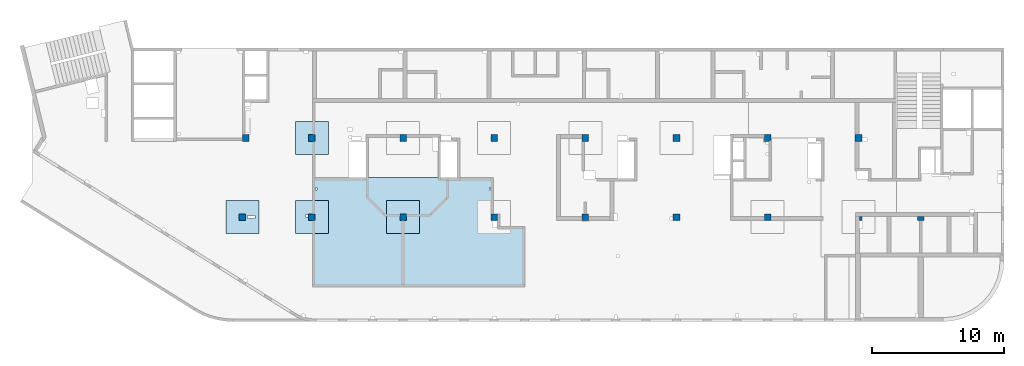
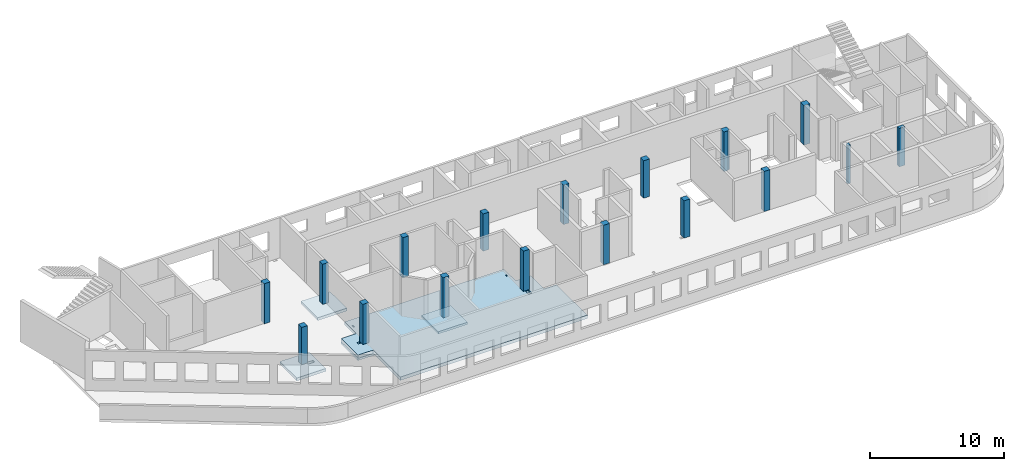
# One storey, part 1 of 10: 17 columns, 5 slabs.
"""IFC4 building model written with IfcOpenShell, lengths in millimetres."""

from ifc_helpers import new_model, entity, si_unit, converted_unit, derived_unit, direction, frame, origin, place, context, subcontext, project, spatial, indexed_curve, outline, extrude, source, transform, mapped, material, type_object, type_shapes, element, save


model = new_model("IFC4")

# Units and contexts
model_context = context("Model", 3, precision=0.01, world=origin(), true_north=direction((6.12303176911189e-17, 1.0)))
plan_context = context("Plan", 3, precision=0.01, world=origin(), true_north=direction((6.12303176911189e-17, 1.0)))
body_context = subcontext(model_context, "Body", "Model", "MODEL_VIEW")
ifc_project = project(units=[si_unit("LENGTHUNIT", "METRE", prefix="MILLI"), si_unit("AREAUNIT", "SQUARE_METRE"), si_unit("VOLUMEUNIT", "CUBIC_METRE"), converted_unit("PLANEANGLEUNIT", "DEGREE", entity("IfcRatioMeasure", 0.0174532925199433), si_unit("PLANEANGLEUNIT", "RADIAN"), dimensions=[0, 0, 0, 0, 0, 0, 0]), si_unit("MASSUNIT", "GRAM", prefix="KILO"), derived_unit("MASSDENSITYUNIT", [(si_unit("MASSUNIT", "GRAM", prefix="KILO"), 1), (si_unit("LENGTHUNIT", "METRE"), -3)]), derived_unit("MOMENTOFINERTIAUNIT", [(si_unit("LENGTHUNIT", "METRE"), 4)]), si_unit("TIMEUNIT", "SECOND"), si_unit("FREQUENCYUNIT", "HERTZ"), si_unit("THERMODYNAMICTEMPERATUREUNIT", "DEGREE_CELSIUS"), derived_unit("THERMALTRANSMITTANCEUNIT", [(si_unit("MASSUNIT", "GRAM", prefix="KILO"), 1), (si_unit("THERMODYNAMICTEMPERATUREUNIT", "KELVIN"), -1), (si_unit("TIMEUNIT", "SECOND"), -3)]), derived_unit("VOLUMETRICFLOWRATEUNIT", [(si_unit("LENGTHUNIT", "METRE"), 3), (si_unit("TIMEUNIT", "SECOND"), -1)]), derived_unit("MASSFLOWRATEUNIT", [(si_unit("MASSUNIT", "GRAM", prefix="KILO"), 1), (si_unit("TIMEUNIT", "SECOND"), -1)]), derived_unit("ROTATIONALFREQUENCYUNIT", [(si_unit("TIMEUNIT", "SECOND"), -1)]), si_unit("ELECTRICCURRENTUNIT", "AMPERE"), si_unit("ELECTRICVOLTAGEUNIT", "VOLT"), si_unit("POWERUNIT", "WATT"), si_unit("FORCEUNIT", "NEWTON", prefix="KILO"), si_unit("ILLUMINANCEUNIT", "LUX"), si_unit("LUMINOUSFLUXUNIT", "LUMEN"), si_unit("LUMINOUSINTENSITYUNIT", "CANDELA"), derived_unit("USERDEFINED", [(si_unit("MASSUNIT", "GRAM", prefix="KILO"), -1), (si_unit("LENGTHUNIT", "METRE"), -2), (si_unit("TIMEUNIT", "SECOND"), 3), (si_unit("LUMINOUSFLUXUNIT", "LUMEN"), 1)]), derived_unit("LINEARVELOCITYUNIT", [(si_unit("LENGTHUNIT", "METRE"), 1), (si_unit("TIMEUNIT", "SECOND"), -1)]), si_unit("PRESSUREUNIT", "PASCAL"), derived_unit("USERDEFINED", [(si_unit("LENGTHUNIT", "METRE"), -2), (si_unit("MASSUNIT", "GRAM", prefix="KILO"), 1), (si_unit("TIMEUNIT", "SECOND"), -2)]), derived_unit("LINEARFORCEUNIT", [(si_unit("MASSUNIT", "GRAM", prefix="KILO"), 1), (si_unit("LENGTHUNIT", "METRE"), 1), (si_unit("TIMEUNIT", "SECOND"), -2), (si_unit("LENGTHUNIT", "METRE"), -1)]), derived_unit("PLANARFORCEUNIT", [(si_unit("MASSUNIT", "GRAM", prefix="KILO"), 1), (si_unit("LENGTHUNIT", "METRE"), 1), (si_unit("TIMEUNIT", "SECOND"), -2), (si_unit("LENGTHUNIT", "METRE"), -2)])], contexts=[model_context, plan_context])

# Site, building, storey
site_placement = place(None, origin())
site = spatial("IfcSite", under=ifc_project, at=site_placement, CompositionType="ELEMENT")
building_placement = place(site_placement, origin())
building = spatial("IfcBuilding", under=site, at=building_placement, CompositionType="ELEMENT")
storey_placement = place(building_placement, frame((0.0, 0.0, 4200.0)))
storey = spatial("IfcBuildingStorey", under=building, at=storey_placement, CompositionType="ELEMENT", Elevation=4200.0)

# Columns
ifc_material = material()
column_type_1 = type_object("IfcColumnType", PredefinedType="COLUMN", material=ifc_material)
shared_shape_1 = source(origin(), body_context, "Body", "SweptSolid", [
    extrude(outline(indexed_curve([(-249.999999999999, -249.999999999999), (250.000000000001, -249.999999999999), (250.000000000001, 249.999999999999), (-249.999999999999, 249.999999999999), (-249.999999999999, -249.999999999999)], self_intersect=False)), frame((15900.0002685547, 7699.99922635634, 4050.0), z_axis=(0.0, 0.0, 1.0), x_axis=(0.0, -1.0, 0.0)), (0.0, 0.0, 1.0), 3400.0),
])
type_shapes(column_type_1, [shared_shape_1])
column_1_placement = place(storey_placement, frame((0.0, 0.0, -4200.0)))
element("IfcColumn", 1, at=column_1_placement, inside=storey, type_object=column_type_1, PredefinedType="COLUMN", context=body_context, shape_type="MappedRepresentation", body=[
    mapped(shared_shape_1, transform((0.0, 0.0, 0.0), scale=1.0)),
])
column_type_2 = type_object("IfcColumnType", PredefinedType="COLUMN", material=ifc_material)
shared_shape_2 = source(origin(), body_context, "Body", "SweptSolid", [
    extrude(outline(indexed_curve([(-249.999999999999, -249.999999999999), (250.000000000001, -249.999999999999), (250.000000000001, 249.999999999999), (-249.999999999999, 249.999999999999), (-249.999999999999, -249.999999999999)], self_intersect=False)), frame((21170.0002685546, 7699.99922635633, 4050.0), z_axis=(0.0, 0.0, 1.0), x_axis=(0.0, -1.0, 0.0)), (0.0, 0.0, 1.0), 3650.0),
])
type_shapes(column_type_2, [shared_shape_2])
column_2_placement = place(storey_placement, frame((0.0, 0.0, -4200.0)))
element("IfcColumn", 2, at=column_2_placement, inside=storey, type_object=column_type_2, PredefinedType="COLUMN", context=body_context, shape_type="MappedRepresentation", body=[
    mapped(shared_shape_2, transform((0.0, 0.0, 0.0), scale=1.0)),
])
column_type_3 = type_object("IfcColumnType", PredefinedType="COLUMN", material=ifc_material)
shared_shape_3 = source(origin(), body_context, "Body", "SweptSolid", [
    extrude(outline(indexed_curve([(-249.999999999999, -249.999999999999), (249.999999999999, -249.999999999999), (249.999999999999, 249.999999999999), (-249.999999999999, 249.999999999999), (-249.999999999999, -249.999999999999)], self_intersect=False)), frame((21170.0002685547, 13699.9992263563, 4050.0), z_axis=(0.0, 0.0, 1.0), x_axis=(0.0, -1.0, 0.0)), (0.0, 0.0, 1.0), 3650.0),
])
type_shapes(column_type_3, [shared_shape_3])
column_3_placement = place(storey_placement, frame((0.0, 0.0, -4200.0)))
element("IfcColumn", 3, at=column_3_placement, inside=storey, type_object=column_type_3, PredefinedType="COLUMN", context=body_context, shape_type="MappedRepresentation", body=[
    mapped(shared_shape_3, transform((0.0, 0.0, 0.0), scale=1.0)),
])
column_type_4 = type_object("IfcColumnType", PredefinedType="COLUMN", material=ifc_material)
shared_shape_4 = source(origin(), body_context, "Body", "SweptSolid", [
    extrude(outline(indexed_curve([(-249.999999999999, -249.999999999999), (249.999999999999, -249.999999999999), (249.999999999999, 249.999999999999), (-249.999999999999, 249.999999999999), (-249.999999999999, -249.999999999999)], self_intersect=False)), frame((28070.0002685547, 13699.9992263563, 4050.0), z_axis=(0.0, 0.0, 1.0), x_axis=(0.0, -1.0, 0.0)), (0.0, 0.0, 1.0), 3650.0),
])
type_shapes(column_type_4, [shared_shape_4])
column_4_placement = place(storey_placement, frame((0.0, 0.0, -4200.0)))
element("IfcColumn", 4, at=column_4_placement, inside=storey, type_object=column_type_4, PredefinedType="COLUMN", context=body_context, shape_type="MappedRepresentation", body=[
    mapped(shared_shape_4, transform((0.0, 0.0, 0.0), scale=1.0)),
])
column_type_5 = type_object("IfcColumnType", PredefinedType="COLUMN", material=ifc_material)
shared_shape_5 = source(origin(), body_context, "Body", "SweptSolid", [
    extrude(outline(indexed_curve([(-249.999999999999, -249.999999999999), (250.000000000001, -249.999999999999), (249.999999999999, 249.999999999999), (-250.000000000001, 249.999999999999), (-249.999999999999, -249.999999999999)], self_intersect=False)), frame((28070.0002685546, 7699.9992263563, 4050.0), z_axis=(0.0, 0.0, 1.0), x_axis=(0.0, -1.0, 0.0)), (0.0, 0.0, 1.0), 3650.0),
])
type_shapes(column_type_5, [shared_shape_5])
column_5_placement = place(storey_placement, frame((0.0, 0.0, -4200.0)))
element("IfcColumn", 5, at=column_5_placement, inside=storey, type_object=column_type_5, PredefinedType="COLUMN", context=body_context, shape_type="MappedRepresentation", body=[
    mapped(shared_shape_5, transform((0.0, 0.0, 0.0), scale=1.0)),
])
column_type_6 = type_object("IfcColumnType", PredefinedType="COLUMN", material=ifc_material)
shared_shape_6 = source(origin(), body_context, "Body", "SweptSolid", [
    extrude(outline(indexed_curve([(-249.999999999999, -249.999999999999), (250.000000000001, -249.999999999999), (250.000000000001, 249.999999999999), (-249.999999999999, 249.999999999999), (-249.999999999999, -249.999999999999)], self_intersect=False)), frame((34970.0002685546, 7699.99922635628, 4050.0), z_axis=(0.0, 0.0, 1.0), x_axis=(0.0, -1.0, 0.0)), (0.0, 0.0, 1.0), 3650.0),
])
type_shapes(column_type_6, [shared_shape_6])
column_6_placement = place(storey_placement, frame((0.0, 0.0, -4200.0)))
element("IfcColumn", 6, at=column_6_placement, inside=storey, type_object=column_type_6, PredefinedType="COLUMN", context=body_context, shape_type="MappedRepresentation", body=[
    mapped(shared_shape_6, transform((0.0, 0.0, 0.0), scale=1.0)),
])
column_type_7 = type_object("IfcColumnType", PredefinedType="COLUMN", material=ifc_material)
shared_shape_7 = source(origin(), body_context, "Body", "SweptSolid", [
    extrude(outline(indexed_curve([(-249.999999999999, -249.999999999999), (249.999999999999, -249.999999999999), (249.999999999999, 249.999999999999), (-249.999999999999, 249.999999999999), (-249.999999999999, -249.999999999999)], self_intersect=False)), frame((34970.0002685546, 13699.9992263563, 4050.0), z_axis=(0.0, 0.0, 1.0), x_axis=(0.0, -1.0, 0.0)), (0.0, 0.0, 1.0), 3400.0),
])
type_shapes(column_type_7, [shared_shape_7])
column_7_placement = place(storey_placement, frame((0.0, 0.0, -4200.0)))
element("IfcColumn", 7, at=column_7_placement, inside=storey, type_object=column_type_7, PredefinedType="COLUMN", context=body_context, shape_type="MappedRepresentation", body=[
    mapped(shared_shape_7, transform((0.0, 0.0, 0.0), scale=1.0)),
])
column_type_8 = type_object("IfcColumnType", PredefinedType="COLUMN", material=ifc_material)
shared_shape_8 = source(origin(), body_context, "Body", "SweptSolid", [
    extrude(outline(indexed_curve([(-249.999999999999, -250.000000000004), (249.999999999999, -250.000000000004), (249.999999999999, 249.999999999995), (-249.999999999999, 250.000000000004), (-249.999999999999, -250.000000000004)], self_intersect=False)), frame((41870.0002685547, 13699.9992263563, 4050.0), z_axis=(0.0, 0.0, 1.0), x_axis=(0.0, -1.0, 0.0)), (0.0, 0.0, 1.0), 3600.0),
])
type_shapes(column_type_8, [shared_shape_8])
column_8_placement = place(storey_placement, frame((0.0, 0.0, -4200.0)))
element("IfcColumn", 8, at=column_8_placement, inside=storey, type_object=column_type_8, PredefinedType="COLUMN", context=body_context, shape_type="MappedRepresentation", body=[
    mapped(shared_shape_8, transform((0.0, 0.0, 0.0), scale=1.0)),
])
column_type_9 = type_object("IfcColumnType", PredefinedType="COLUMN", material=ifc_material)
shared_shape_9 = source(origin(), body_context, "Body", "SweptSolid", [
    extrude(outline(indexed_curve([(-249.999999999999, -250.000000000004), (250.000000000001, -250.000000000004), (249.999999999999, 249.999999999995), (-250.000000000001, 250.000000000004), (-249.999999999999, -250.000000000004)], self_intersect=False)), frame((41870.0002685547, 7699.99922635626, 4050.0), z_axis=(0.0, 0.0, 1.0), x_axis=(0.0, -1.0, 0.0)), (0.0, 0.0, 1.0), 3600.0),
])
type_shapes(column_type_9, [shared_shape_9])
column_9_placement = place(storey_placement, frame((0.0, 0.0, -4200.0)))
element("IfcColumn", 9, at=column_9_placement, inside=storey, type_object=column_type_9, PredefinedType="COLUMN", context=body_context, shape_type="MappedRepresentation", body=[
    mapped(shared_shape_9, transform((0.0, 0.0, 0.0), scale=1.0)),
])
column_type_10 = type_object("IfcColumnType", PredefinedType="COLUMN", material=ifc_material)
shared_shape_10 = source(origin(), body_context, "Body", "SweptSolid", [
    extrude(outline(indexed_curve([(-249.999999999999, -250.000000000004), (250.000000000001, -250.000000000004), (250.000000000001, 249.999999999995), (-249.999999999999, 250.000000000004), (-249.999999999999, -250.000000000004)], self_intersect=False)), frame((48770.0002685546, 7699.99922635624, 4050.0), z_axis=(0.0, 0.0, 1.0), x_axis=(0.0, -1.0, 0.0)), (0.0, 0.0, 1.0), 3400.0),
])
type_shapes(column_type_10, [shared_shape_10])
column_10_placement = place(storey_placement, frame((0.0, 0.0, -4200.0)))
element("IfcColumn", 10, at=column_10_placement, inside=storey, type_object=column_type_10, PredefinedType="COLUMN", context=body_context, shape_type="MappedRepresentation", body=[
    mapped(shared_shape_10, transform((0.0, 0.0, 0.0), scale=1.0)),
])
column_type_11 = type_object("IfcColumnType", PredefinedType="COLUMN", material=ifc_material)
shared_shape_11 = source(origin(), body_context, "Body", "SweptSolid", [
    extrude(outline(indexed_curve([(-249.999999999999, -250.000000000004), (249.999999999999, -250.000000000004), (249.999999999999, 249.999999999995), (-249.999999999999, 250.000000000004), (-249.999999999999, -250.000000000004)], self_intersect=False)), frame((48770.0002685547, 13699.9992263562, 4050.0), z_axis=(0.0, 0.0, 1.0), x_axis=(0.0, -1.0, 0.0)), (0.0, 0.0, 1.0), 3400.0),
])
type_shapes(column_type_11, [shared_shape_11])
column_11_placement = place(storey_placement, frame((0.0, 0.0, -4200.0)))
element("IfcColumn", 11, at=column_11_placement, inside=storey, type_object=column_type_11, PredefinedType="COLUMN", context=body_context, shape_type="MappedRepresentation", body=[
    mapped(shared_shape_11, transform((0.0, 0.0, 0.0), scale=1.0)),
])
column_type_12 = type_object("IfcColumnType", PredefinedType="COLUMN", material=ifc_material)
shared_shape_12 = source(origin(), body_context, "Body", "SweptSolid", [
    extrude(outline(indexed_curve([(-316.666666666675, -283.333333333321), (183.333333333324, -283.333333333321), (183.333333333324, 66.6666666666602), (133.333333333353, 66.6666666666602), (133.333333333353, 216.666666666687), (-316.666666666675, 216.666666666687), (-316.666666666675, -283.333333333321)], self_intersect=False)), frame((55703.333601888, 13633.3325596895, 4050.0), z_axis=(0.0, 0.0, 1.0), x_axis=(0.0, -1.0, 0.0)), (0.0, 0.0, 1.0), 3600.0),
])
type_shapes(column_type_12, [shared_shape_12])
column_12_placement = place(storey_placement, frame((0.0, 0.0, -4200.0)))
element("IfcColumn", 12, at=column_12_placement, inside=storey, type_object=column_type_12, PredefinedType="COLUMN", context=body_context, shape_type="MappedRepresentation", body=[
    mapped(shared_shape_12, transform((0.0, 0.0, 0.0), scale=1.0)),
])
column_type_13 = type_object("IfcColumnType", PredefinedType="COLUMN", material=ifc_material)
shared_shape_13 = source(origin(), body_context, "Body", "SweptSolid", [
    extrude(outline(indexed_curve([(-249.999999999999, -250.000000000004), (250.000000000001, -250.000000000004), (249.999999999999, 249.999999999995), (-250.000000000001, 250.000000000004), (-249.999999999999, -250.000000000004)], self_intersect=False)), frame((55670.0002685547, 7699.99922635621, 4050.0), z_axis=(0.0, 0.0, 1.0), x_axis=(0.0, -1.0, 0.0)), (0.0, 0.0, 1.0), 3650.0),
])
type_shapes(column_type_13, [shared_shape_13])
column_13_placement = place(storey_placement, frame((0.0, 0.0, -4200.0)))
element("IfcColumn", 13, at=column_13_placement, inside=storey, type_object=column_type_13, PredefinedType="COLUMN", context=body_context, shape_type="MappedRepresentation", body=[
    mapped(shared_shape_13, transform((0.0, 0.0, 0.0), scale=1.0)),
])
column_type_14 = type_object("IfcColumnType", PredefinedType="COLUMN", material=ifc_material)
shared_shape_14 = source(origin(), body_context, "Body", "SweptSolid", [
    extrude(outline(indexed_curve([(-149.99999999991, -99.9999999999946), (149.99999999991, -99.9999999999946), (149.99999999991, 100.000000000003), (-149.99999999991, 100.000000000012), (-149.99999999991, -99.9999999999946)], self_intersect=False)), frame((62720.0002685546, 7599.9992263561, 4050.0), z_axis=(0.0, 0.0, 1.0), x_axis=(0.0, -1.0, 0.0)), (0.0, 0.0, 1.0), 3500.0),
])
type_shapes(column_type_14, [shared_shape_14])
column_14_placement = place(storey_placement, frame((0.0, 0.0, -4200.0)))
element("IfcColumn", 14, at=column_14_placement, inside=storey, type_object=column_type_14, PredefinedType="COLUMN", context=body_context, shape_type="MappedRepresentation", body=[
    mapped(shared_shape_14, transform((0.0, 0.0, 0.0), scale=1.0)),
])
column_type_15 = type_object("IfcColumnType", PredefinedType="COLUMN", material=ifc_material)
shared_shape_15 = source(origin(), body_context, "Body", "SweptSolid", [
    extrude(outline(indexed_curve([(-249.999999999999, -262.500000000001), (249.999999999999, -262.500000000001), (249.999999999999, 262.500000000001), (-249.999999999999, 262.500000000001), (-249.999999999999, -262.500000000001)], self_intersect=False)), frame((62557.5002685547, 13699.9992263562, 4050.0), z_axis=(0.0, 0.0, 1.0), x_axis=(0.0, -1.0, 0.0)), (0.0, 0.0, 1.0), 3600.0),
])
type_shapes(column_type_15, [shared_shape_15])
column_15_placement = place(storey_placement, frame((0.0, 0.0, -4200.0)))
element("IfcColumn", 15, at=column_15_placement, inside=storey, type_object=column_type_15, PredefinedType="COLUMN", context=body_context, shape_type="MappedRepresentation", body=[
    mapped(shared_shape_15, transform((0.0, 0.0, 0.0), scale=1.0)),
])
column_type_16 = type_object("IfcColumnType", PredefinedType="COLUMN", material=ifc_material)
shared_shape_16 = source(origin(), body_context, "Body", "SweptSolid", [
    extrude(outline(indexed_curve([(-249.999999999999, -249.999999999999), (249.999999999999, -249.999999999999), (249.999999999999, 249.999999999999), (-249.999999999999, 249.999999999999), (-249.999999999999, -249.999999999999)], self_intersect=False)), frame((16150.0002685547, 13699.9992263563, 4050.0), z_axis=(0.0, 0.0, 1.0), x_axis=(0.0, -1.0, 0.0)), (0.0, 0.0, 1.0), 3650.0),
])
type_shapes(column_type_16, [shared_shape_16])
column_16_placement = place(storey_placement, frame((0.0, 0.0, -4200.0)))
element("IfcColumn", 16, at=column_16_placement, inside=storey, type_object=column_type_16, PredefinedType="COLUMN", context=body_context, shape_type="MappedRepresentation", body=[
    mapped(shared_shape_16, transform((0.0, 0.0, 0.0), scale=1.0)),
])
column_type_17 = type_object("IfcColumnType", PredefinedType="COLUMN", material=ifc_material)
shared_shape_17 = source(origin(), body_context, "Body", "SweptSolid", [
    extrude(outline(indexed_curve([(-149.999999999912, -249.999999999995), (149.999999999911, -249.999999999995), (149.999999999911, 250.000000000004), (-149.999999999911, 250.000000000012), (-149.999999999912, -249.999999999995)], self_intersect=False)), frame((67270.0002685546, 7599.99922635609, 4050.0), z_axis=(0.0, 0.0, 1.0), x_axis=(0.0, -1.0, 0.0)), (0.0, 0.0, 1.0), 3500.0),
])
type_shapes(column_type_17, [shared_shape_17])
column_17_placement = place(storey_placement, frame((0.0, 0.0, -4200.0)))
element("IfcColumn", 17, at=column_17_placement, inside=storey, type_object=column_type_17, PredefinedType="COLUMN", context=body_context, shape_type="MappedRepresentation", body=[
    mapped(shared_shape_17, transform((0.0, 0.0, 0.0), scale=1.0)),
])

# Slabs
slab_type_1 = type_object("IfcSlabType", PredefinedType="FLOOR", material=ifc_material)
slab_1_placement = place(storey_placement, origin())
element("IfcSlab", 18, at=slab_1_placement, inside=storey, type_object=slab_type_1, material=ifc_material, PredefinedType="FLOOR", context=body_context, shape_type="SweptSolid", body=[
    extrude(outline(indexed_curve([(-722.500000000044, -8448.74999999999), (1777.49999999996, -8448.74999999999), (1777.49999999996, -7148.75), (5827.50000000003, -7148.75), (5827.50000000006, 8926.24999999999), (1227.50000000005, 8926.25), (1227.50000000005, 7851.25), (-722.500000000003, 7851.25), (-722.500000000005, 6551.25), (-2462.49999999999, 6551.25), (-2462.5, 3801.24999999999), (-2462.5, 2531.25000000001), (-2462.50000000001, -3118.75), (-2462.50000000001, -4378.75000000001), (-2462.50000000001, -7148.74999999999), (-722.500000000042, -7148.75), (-722.500000000044, -8448.74999999999)], self_intersect=False), holes=[indexed_curve([(327.499999999815, -7498.75), (527.499999999955, -7498.75), (527.499999999955, -7698.75000000001), (327.499999999815, -7698.75000000001), (327.499999999815, -7498.75)], self_intersect=False), indexed_curve([(-1742.50000000021, 6331.24999999997), (-1542.5000000002, 6331.24999999997), (-1542.5000000002, 6231.24999999997), (-1742.50000000021, 6231.24999999997), (-1742.50000000021, 6331.24999999997)], self_intersect=False), indexed_curve([(827.499999999798, 6801.24999999999), (1287.4999999998, 6801.24999999999), (1287.4999999998, 6481.24999999999), (827.499999999798, 6481.24999999999), (827.499999999798, 6801.24999999999)], self_intersect=False), indexed_curve([(-1742.50000000018, -6828.75000000001), (-1542.50000000018, -6828.75), (-1542.50000000018, -6928.75000000002), (-1742.50000000018, -6928.75000000002), (-1742.50000000018, -6828.75000000001)], self_intersect=False)]), frame((28368.7502685546, 8227.49922635627, -450.0), z_axis=(0.0, 0.0, 1.0), x_axis=(0.0, -1.0, 0.0)), (0.0, 0.0, 1.0), 300.0),
])
slab_type_2 = type_object("IfcSlabType", PredefinedType="FLOOR", material=ifc_material)
slab_2_placement = place(storey_placement, origin())
element("IfcSlab", 19, at=slab_2_placement, inside=storey, type_object=slab_type_2, material=ifc_material, PredefinedType="FLOOR", context=body_context, shape_type="SweptSolid", body=[
    extrude(outline(indexed_curve([(-1250.0, -1250.0), (1250.0, -1250.0), (1250.0, 1250.0), (-1250.0, 1250.0), (-1250.0, -1250.0)], self_intersect=False), holes=[indexed_curve([(300.000000000001, -200.000000000139), (300.000000000001, 1.08286712929839e-12), (500.000000000016, 1.08286712929839e-12), (500.000000000016, -200.000000000139), (300.000000000001, -200.000000000139)], self_intersect=False)]), frame((21170.0002685546, 7699.99922635633, -650.0), z_axis=(0.0, 0.0, 1.0), x_axis=(-1.0, 0.0, 0.0)), (0.0, 0.0, 1.0), 200.0),
])
slab_type_3 = type_object("IfcSlabType", PredefinedType="FLOOR", material=ifc_material)
slab_3_placement = place(storey_placement, origin())
element("IfcSlab", 20, at=slab_3_placement, inside=storey, type_object=slab_type_3, material=ifc_material, PredefinedType="FLOOR", context=body_context, shape_type="SweptSolid", body=[
    extrude(outline(indexed_curve([(-1250.0, -1250.0), (1250.0, -1250.0), (1250.0, 1250.0), (-1250.0, 1250.0), (-1250.0, -1250.0)], self_intersect=False)), frame((28070.0002685546, 7699.9992263563, -450.0), z_axis=(0.0, 0.0, -1.0), x_axis=(0.0, 1.0, 0.0)), (0.0, 0.0, 1.0), 200.0),
])
slab_type_4 = type_object("IfcSlabType", PredefinedType="FLOOR", material=ifc_material)
slab_4_placement = place(storey_placement, origin())
element("IfcSlab", 21, at=slab_4_placement, inside=storey, type_object=slab_type_4, material=ifc_material, PredefinedType="FLOOR", context=body_context, shape_type="SweptSolid", body=[
    extrude(outline(indexed_curve([(-1250.0, -1250.0), (1250.0, -1250.0), (1250.0, 1250.0), (-1250.0, 1250.0), (-1250.0, -1250.0)], self_intersect=False), holes=[indexed_curve([(-949.999999999979, -150.000000000118), (-949.999999999979, 99.9999999998776), (-389.999999999968, 99.9999999998776), (-389.999999999968, -150.000000000118), (-949.999999999979, -150.000000000118)], self_intersect=False)]), frame((15900.0002685547, 7699.99922635634, -650.0), z_axis=(0.0, 0.0, 1.0), x_axis=(-1.0, 0.0, 0.0)), (0.0, 0.0, 1.0), 250.0),
])
slab_type_5 = type_object("IfcSlabType", PredefinedType="FLOOR", material=ifc_material)
slab_5_placement = place(storey_placement, origin())
element("IfcSlab", 22, at=slab_5_placement, inside=storey, type_object=slab_type_5, material=ifc_material, PredefinedType="FLOOR", context=body_context, shape_type="SweptSolid", body=[
    extrude(outline(indexed_curve([(-1250.0, -1250.0), (1250.0, -1250.0), (1250.0, 1250.0), (-1250.0, 1250.0), (-1250.0, -1250.0)], self_intersect=False)), frame((21170.0002685547, 13699.9992263563, -400.0), z_axis=(0.0, 0.0, -1.0), x_axis=(0.0, 1.0, 0.0)), (0.0, 0.0, 1.0), 250.0),
])

save(model, "model.ifc")
